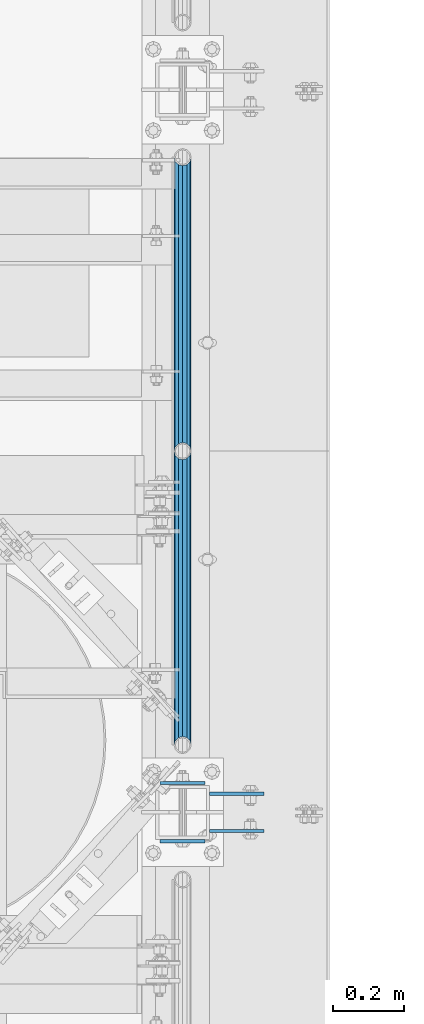
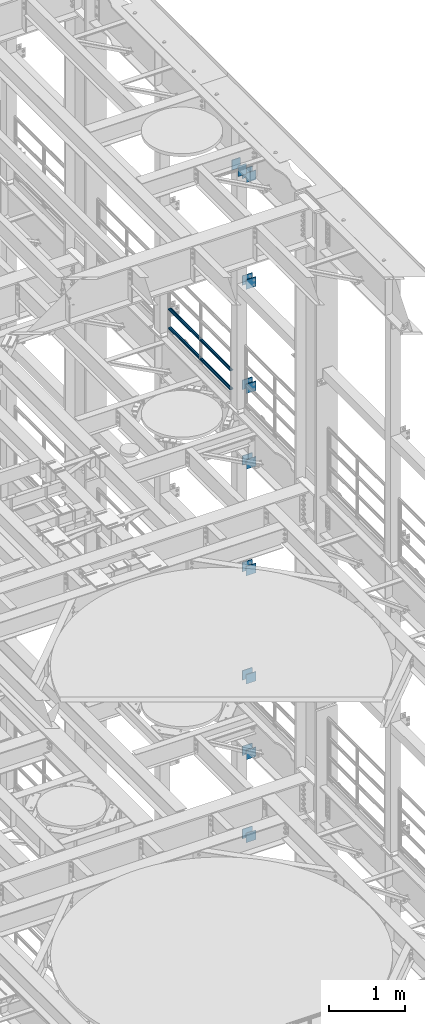
# One storey, part 1278 of 1876: 22 beams, 5 elements without a shape of their own.
"""IFC2X3 building model written with IfcOpenShell, lengths in millimetres."""

from ifc_helpers import new_model, si_unit, frame, origin_with_axes, place, context, subcontext, project, spatial, faceted_brep, material, type_object, element, aggregate, save


model = new_model("IFC2X3")

# Units and contexts
model_context = context("Model", 3, precision=1e-05, world=origin_with_axes())
body_context = subcontext(model_context, "Body", "Model", "MODEL_VIEW")
ifc_project = project(units=[si_unit("LENGTHUNIT", "METRE", prefix="MILLI"), si_unit("AREAUNIT", "SQUARE_METRE"), si_unit("VOLUMEUNIT", "CUBIC_METRE"), si_unit("MASSUNIT", "GRAM", prefix="KILO"), si_unit("TIMEUNIT", "SECOND"), si_unit("PLANEANGLEUNIT", "RADIAN"), si_unit("SOLIDANGLEUNIT", "STERADIAN"), si_unit("THERMODYNAMICTEMPERATUREUNIT", "DEGREE_CELSIUS"), si_unit("LUMINOUSINTENSITYUNIT", "LUMEN")], contexts=[model_context])

# Site, building, storey
site_placement = place(None, origin_with_axes())
site = spatial("IfcSite", under=ifc_project, at=site_placement, CompositionType="ELEMENT")
building_placement = place(site_placement, origin_with_axes())
building = spatial("IfcBuilding", under=site, at=building_placement, Name="Undefined", CompositionType="ELEMENT")
storey_placement = place(building_placement, origin_with_axes())
storey = spatial("IfcBuildingStorey", under=building, at=storey_placement, Name="Undefined", CompositionType="ELEMENT", Elevation=0.0)

# Assembly, beams
assembly_1_placement = place(storey_placement, origin_with_axes())
assembly_1 = element("IfcElementAssembly", 1, at=assembly_1_placement, inside=storey, Name="BEAM", AssemblyPlace="NOTDEFINED", PredefinedType="RIGID_FRAME")
ifc_material_1 = material(Name="STEEL/A36")
beam_type_1 = type_object("IfcBeamType", PredefinedType="NOTDEFINED")
beam_1_placement = place(assembly_1_placement, frame((7696.20000025489, 3608.3875, 18275.3), z_axis=(0.0, 0.0, -1.0), x_axis=(1.0, 0.0, 0.0)))
beam_1 = element("IfcBeam", 2, at=beam_1_placement, type_object=beam_type_1, material=ifc_material_1, Name="PLATE", context=body_context, shape_type="Brep", body=[
    faceted_brep([(0.0, 4.76249999999982, -76.1999999999998), (3.63797880709171e-12, 4.76249999999982, 76.1999969482422), (152.399993896484, 4.76250000000073, 76.1999969482422), (152.4, 4.76249999999982, -76.1999999999998), (3.63797880709171e-12, -4.76249999999982, 76.1999969482422), (152.399993896484, -4.76250000000073, 76.1999969482422), (0.0, -4.76249999999982, -76.1999999999998), (152.4, -4.76249999999982, -76.1999999999998)], [[[0, 1, 2, 3]], [[4, 5, 2, 1]], [[4, 6, 7, 5]], [[6, 0, 3, 7]], [[5, 7, 3, 2]], [[6, 4, 1, 0]]]),
])
beam_2_placement = place(assembly_1_placement, frame((7696.20000025489, 3503.6125, 18275.3), z_axis=(0.0, 0.0, -1.0), x_axis=(1.0, 0.0, 0.0)))
beam_2 = element("IfcBeam", 3, at=beam_2_placement, type_object=beam_type_1, material=ifc_material_1, Name="PLATE", context=body_context, shape_type="Brep", body=[
    faceted_brep([(0.0, 4.76249999999982, -76.1999999999998), (3.63797880709171e-12, 4.76249999999982, 76.1999969482422), (152.399993896484, 4.76250000000073, 76.1999969482422), (152.4, 4.76249999999982, -76.1999999999998), (3.63797880709171e-12, -4.76249999999982, 76.1999969482422), (152.399993896484, -4.76250000000073, 76.1999969482422), (0.0, -4.76249999999982, -76.1999999999998), (152.4, -4.76249999999982, -76.1999999999998)], [[[0, 1, 2, 3]], [[4, 5, 2, 1]], [[4, 6, 7, 5]], [[6, 0, 3, 7]], [[5, 7, 3, 2]], [[6, 4, 1, 0]]]),
])
beam_3_placement = place(assembly_1_placement, frame((7696.20000025489, 3608.3875, 21678.9), z_axis=(0.0, 0.0, -1.0), x_axis=(1.0, 0.0, 0.0)))
beam_3 = element("IfcBeam", 4, at=beam_3_placement, type_object=beam_type_1, material=ifc_material_1, Name="PLATE", context=body_context, shape_type="Brep", body=[
    faceted_brep([(0.0, 4.76249999999982, -76.1999999999998), (3.63797880709171e-12, 4.76249999999982, 76.1999969482422), (152.399993896484, 4.76250000000073, 76.1999969482422), (152.4, 4.76249999999982, -76.1999999999998), (3.63797880709171e-12, -4.76249999999982, 76.1999969482422), (152.399993896484, -4.76250000000073, 76.1999969482422), (0.0, -4.76249999999982, -76.1999999999998), (152.4, -4.76249999999982, -76.1999999999998)], [[[0, 1, 2, 3]], [[4, 5, 2, 1]], [[4, 6, 7, 5]], [[6, 0, 3, 7]], [[5, 7, 3, 2]], [[6, 4, 1, 0]]]),
])
beam_4_placement = place(assembly_1_placement, frame((7696.20000025489, 3503.6125, 21678.9), z_axis=(0.0, 0.0, -1.0), x_axis=(1.0, 0.0, 0.0)))
beam_4 = element("IfcBeam", 5, at=beam_4_placement, type_object=beam_type_1, material=ifc_material_1, Name="PLATE", context=body_context, shape_type="Brep", body=[
    faceted_brep([(0.0, 4.76249999999982, -76.1999999999998), (3.63797880709171e-12, 4.76249999999982, 76.1999969482422), (152.399993896484, 4.76250000000073, 76.1999969482422), (152.4, 4.76249999999982, -76.1999999999998), (3.63797880709171e-12, -4.76249999999982, 76.1999969482422), (152.399993896484, -4.76250000000073, 76.1999969482422), (0.0, -4.76249999999982, -76.1999999999998), (152.4, -4.76249999999982, -76.1999999999998)], [[[0, 1, 2, 3]], [[4, 5, 2, 1]], [[4, 6, 7, 5]], [[6, 0, 3, 7]], [[5, 7, 3, 2]], [[6, 4, 1, 0]]]),
])
beam_5_placement = place(assembly_1_placement, frame((7696.20000025489, 3608.3875, 19958.05), z_axis=(0.0, 0.0, -1.0), x_axis=(1.0, 0.0, 0.0)))
beam_5 = element("IfcBeam", 6, at=beam_5_placement, type_object=beam_type_1, material=ifc_material_1, Name="PLATE", context=body_context, shape_type="Brep", body=[
    faceted_brep([(0.0, 4.76249999999982, -76.1999999999998), (3.63797880709171e-12, 4.76249999999982, 76.1999969482422), (152.399993896484, 4.76250000000073, 76.1999969482422), (152.4, 4.76249999999982, -76.1999999999998), (3.63797880709171e-12, -4.76249999999982, 76.1999969482422), (152.399993896484, -4.76250000000073, 76.1999969482422), (0.0, -4.76249999999982, -76.1999999999998), (152.4, -4.76249999999982, -76.1999999999998)], [[[0, 1, 2, 3]], [[4, 5, 2, 1]], [[4, 6, 7, 5]], [[6, 0, 3, 7]], [[5, 7, 3, 2]], [[6, 4, 1, 0]]]),
])
beam_6_placement = place(assembly_1_placement, frame((7696.20000025489, 3503.6125, 19958.05), z_axis=(0.0, 0.0, -1.0), x_axis=(1.0, 0.0, 0.0)))
beam_6 = element("IfcBeam", 7, at=beam_6_placement, type_object=beam_type_1, material=ifc_material_1, Name="PLATE", context=body_context, shape_type="Brep", body=[
    faceted_brep([(0.0, 4.76249999999982, -76.1999999999998), (3.63797880709171e-12, 4.76249999999982, 76.1999969482422), (152.399993896484, 4.76250000000073, 76.1999969482422), (152.4, 4.76249999999982, -76.1999999999998), (3.63797880709171e-12, -4.76249999999982, 76.1999969482422), (152.399993896484, -4.76250000000073, 76.1999969482422), (0.0, -4.76249999999982, -76.1999999999998), (152.4, -4.76249999999982, -76.1999999999998)], [[[0, 1, 2, 3]], [[4, 5, 2, 1]], [[4, 6, 7, 5]], [[6, 0, 3, 7]], [[5, 7, 3, 2]], [[6, 4, 1, 0]]]),
])
aggregate(assembly_1, [beam_1, beam_2, beam_3, beam_4, beam_5, beam_6])

assembly_2_placement = place(storey_placement, origin_with_axes())
assembly_2 = element("IfcElementAssembly", 8, at=assembly_2_placement, inside=storey, Name="BEAM", AssemblyPlace="NOTDEFINED", PredefinedType="RIGID_FRAME")
beam_7_placement = place(assembly_2_placement, frame((7696.2, 3608.3875, 13589.0), z_axis=(0.0, 0.0, -1.0), x_axis=(1.0, 0.0, 0.0)))
beam_7 = element("IfcBeam", 9, at=beam_7_placement, type_object=beam_type_1, material=ifc_material_1, Name="PLATE", context=body_context, shape_type="Brep", body=[
    faceted_brep([(0.0, 4.76249999999982, -76.1999999999998), (3.63797880709171e-12, 4.76249999999982, 76.1999969482422), (152.399993896484, 4.76250000000073, 76.1999969482422), (152.4, 4.76249999999982, -76.1999999999998), (3.63797880709171e-12, -4.76249999999982, 76.1999969482422), (152.399993896484, -4.76250000000073, 76.1999969482422), (0.0, -4.76249999999982, -76.1999999999998), (152.4, -4.76249999999982, -76.1999999999998)], [[[0, 1, 2, 3]], [[4, 5, 2, 1]], [[4, 6, 7, 5]], [[6, 0, 3, 7]], [[5, 7, 3, 2]], [[6, 4, 1, 0]]]),
])
beam_8_placement = place(assembly_2_placement, frame((7696.2, 3503.6125, 13589.0), z_axis=(0.0, 0.0, -1.0), x_axis=(1.0, 0.0, 0.0)))
beam_8 = element("IfcBeam", 10, at=beam_8_placement, type_object=beam_type_1, material=ifc_material_1, Name="PLATE", context=body_context, shape_type="Brep", body=[
    faceted_brep([(0.0, 4.76249999999982, -76.1999999999998), (3.63797880709171e-12, 4.76249999999982, 76.1999969482422), (152.399993896484, 4.76250000000073, 76.1999969482422), (152.4, 4.76249999999982, -76.1999999999998), (3.63797880709171e-12, -4.76249999999982, 76.1999969482422), (152.399993896484, -4.76250000000073, 76.1999969482422), (0.0, -4.76249999999982, -76.1999999999998), (152.4, -4.76249999999982, -76.1999999999998)], [[[0, 1, 2, 3]], [[4, 5, 2, 1]], [[4, 6, 7, 5]], [[6, 0, 3, 7]], [[5, 7, 3, 2]], [[6, 4, 1, 0]]]),
])
beam_9_placement = place(assembly_2_placement, frame((7696.2, 3608.3875, 17056.1), z_axis=(0.0, 0.0, -1.0), x_axis=(1.0, 0.0, 0.0)))
beam_9 = element("IfcBeam", 11, at=beam_9_placement, type_object=beam_type_1, material=ifc_material_1, Name="PLATE", context=body_context, shape_type="Brep", body=[
    faceted_brep([(0.0, 4.76249999999982, -76.1999999999998), (3.63797880709171e-12, 4.76249999999982, 76.1999969482422), (152.399993896484, 4.76250000000073, 76.1999969482422), (152.4, 4.76249999999982, -76.1999999999998), (3.63797880709171e-12, -4.76249999999982, 76.1999969482422), (152.399993896484, -4.76250000000073, 76.1999969482422), (0.0, -4.76249999999982, -76.1999999999998), (152.4, -4.76249999999982, -76.1999999999998)], [[[0, 1, 2, 3]], [[4, 5, 2, 1]], [[4, 6, 7, 5]], [[6, 0, 3, 7]], [[5, 7, 3, 2]], [[6, 4, 1, 0]]]),
])
beam_10_placement = place(assembly_2_placement, frame((7696.2, 3503.6125, 17056.1), z_axis=(0.0, 0.0, -1.0), x_axis=(1.0, 0.0, 0.0)))
beam_10 = element("IfcBeam", 12, at=beam_10_placement, type_object=beam_type_1, material=ifc_material_1, Name="PLATE", context=body_context, shape_type="Brep", body=[
    faceted_brep([(0.0, 4.76249999999982, -76.1999999999998), (3.63797880709171e-12, 4.76249999999982, 76.1999969482422), (152.399993896484, 4.76250000000073, 76.1999969482422), (152.4, 4.76249999999982, -76.1999999999998), (3.63797880709171e-12, -4.76249999999982, 76.1999969482422), (152.399993896484, -4.76250000000073, 76.1999969482422), (0.0, -4.76249999999982, -76.1999999999998), (152.4, -4.76249999999982, -76.1999999999998)], [[[0, 1, 2, 3]], [[4, 5, 2, 1]], [[4, 6, 7, 5]], [[6, 0, 3, 7]], [[5, 7, 3, 2]], [[6, 4, 1, 0]]]),
])
beam_11_placement = place(assembly_2_placement, frame((7696.2, 3608.3875, 15335.25), z_axis=(0.0, 0.0, -1.0), x_axis=(1.0, 0.0, 0.0)))
beam_11 = element("IfcBeam", 13, at=beam_11_placement, type_object=beam_type_1, material=ifc_material_1, Name="PLATE", context=body_context, shape_type="Brep", body=[
    faceted_brep([(0.0, 4.76249999999982, -76.1999999999998), (3.63797880709171e-12, 4.76249999999982, 76.1999969482422), (152.399993896484, 4.76250000000073, 76.1999969482422), (152.4, 4.76249999999982, -76.1999999999998), (3.63797880709171e-12, -4.76249999999982, 76.1999969482422), (152.399993896484, -4.76250000000073, 76.1999969482422), (0.0, -4.76249999999982, -76.1999999999998), (152.4, -4.76249999999982, -76.1999999999998)], [[[0, 1, 2, 3]], [[4, 5, 2, 1]], [[4, 6, 7, 5]], [[6, 0, 3, 7]], [[5, 7, 3, 2]], [[6, 4, 1, 0]]]),
])
beam_12_placement = place(assembly_2_placement, frame((7696.2, 3503.6125, 15335.25), z_axis=(0.0, 0.0, -1.0), x_axis=(1.0, 0.0, 0.0)))
beam_12 = element("IfcBeam", 14, at=beam_12_placement, type_object=beam_type_1, material=ifc_material_1, Name="PLATE", context=body_context, shape_type="Brep", body=[
    faceted_brep([(0.0, 4.76249999999982, -76.1999999999998), (3.63797880709171e-12, 4.76249999999982, 76.1999969482422), (152.399993896484, 4.76250000000073, 76.1999969482422), (152.4, 4.76249999999982, -76.1999999999998), (3.63797880709171e-12, -4.76249999999982, 76.1999969482422), (152.399993896484, -4.76250000000073, 76.1999969482422), (0.0, -4.76249999999982, -76.1999999999998), (152.4, -4.76249999999982, -76.1999999999998)], [[[0, 1, 2, 3]], [[4, 5, 2, 1]], [[4, 6, 7, 5]], [[6, 0, 3, 7]], [[5, 7, 3, 2]], [[6, 4, 1, 0]]]),
])
aggregate(assembly_2, [beam_7, beam_8, beam_9, beam_10, beam_11, beam_12])

assembly_3_placement = place(storey_placement, origin_with_axes())
assembly_3 = element("IfcElementAssembly", 15, at=assembly_3_placement, inside=storey, Name="BEAM", AssemblyPlace="NOTDEFINED", PredefinedType="RIGID_FRAME")
beam_13_placement = place(assembly_3_placement, frame((7696.2, 3608.3875, 12369.8), z_axis=(0.0, 0.0, -1.0), x_axis=(1.0, 0.0, 0.0)))
beam_13 = element("IfcBeam", 16, at=beam_13_placement, type_object=beam_type_1, material=ifc_material_1, Name="PLATE", context=body_context, shape_type="Brep", body=[
    faceted_brep([(0.0, 4.76249999999982, -76.1999999999998), (3.63797880709171e-12, 4.76249999999982, 76.1999969482422), (152.399993896484, 4.76250000000073, 76.1999969482422), (152.4, 4.76249999999982, -76.1999999999998), (3.63797880709171e-12, -4.76249999999982, 76.1999969482422), (152.399993896484, -4.76250000000073, 76.1999969482422), (0.0, -4.76249999999982, -76.1999999999998), (152.4, -4.76249999999982, -76.1999999999998)], [[[0, 1, 2, 3]], [[4, 5, 2, 1]], [[4, 6, 7, 5]], [[6, 0, 3, 7]], [[5, 7, 3, 2]], [[6, 4, 1, 0]]]),
])
beam_14_placement = place(assembly_3_placement, frame((7696.2, 3503.6125, 12369.8), z_axis=(0.0, 0.0, -1.0), x_axis=(1.0, 0.0, 0.0)))
beam_14 = element("IfcBeam", 17, at=beam_14_placement, type_object=beam_type_1, material=ifc_material_1, Name="PLATE", context=body_context, shape_type="Brep", body=[
    faceted_brep([(0.0, 4.76249999999982, -76.1999999999998), (3.63797880709171e-12, 4.76249999999982, 76.1999969482422), (152.399993896484, 4.76250000000073, 76.1999969482422), (152.4, 4.76249999999982, -76.1999999999998), (3.63797880709171e-12, -4.76249999999982, 76.1999969482422), (152.399993896484, -4.76250000000073, 76.1999969482422), (0.0, -4.76249999999982, -76.1999999999998), (152.4, -4.76249999999982, -76.1999999999998)], [[[0, 1, 2, 3]], [[4, 5, 2, 1]], [[4, 6, 7, 5]], [[6, 0, 3, 7]], [[5, 7, 3, 2]], [[6, 4, 1, 0]]]),
])
beam_15_placement = place(assembly_3_placement, frame((7696.2, 3608.3875, 11029.95), z_axis=(0.0, 0.0, -1.0), x_axis=(1.0, 0.0, 0.0)))
beam_15 = element("IfcBeam", 18, at=beam_15_placement, type_object=beam_type_1, material=ifc_material_1, Name="PLATE", context=body_context, shape_type="Brep", body=[
    faceted_brep([(0.0, 4.76249999999982, -76.1999999999998), (3.63797880709171e-12, 4.76249999999982, 76.1999969482422), (152.399993896484, 4.76250000000073, 76.1999969482422), (152.4, 4.76249999999982, -76.1999999999998), (3.63797880709171e-12, -4.76249999999982, 76.1999969482422), (152.399993896484, -4.76250000000073, 76.1999969482422), (0.0, -4.76249999999982, -76.1999999999998), (152.4, -4.76249999999982, -76.1999999999998)], [[[0, 1, 2, 3]], [[4, 5, 2, 1]], [[4, 6, 7, 5]], [[6, 0, 3, 7]], [[5, 7, 3, 2]], [[6, 4, 1, 0]]]),
])
beam_16_placement = place(assembly_3_placement, frame((7696.2, 3503.6125, 11029.95), z_axis=(0.0, 0.0, -1.0), x_axis=(1.0, 0.0, 0.0)))
beam_16 = element("IfcBeam", 19, at=beam_16_placement, type_object=beam_type_1, material=ifc_material_1, Name="PLATE", context=body_context, shape_type="Brep", body=[
    faceted_brep([(0.0, 4.76249999999982, -76.1999999999998), (3.63797880709171e-12, 4.76249999999982, 76.1999969482422), (152.399993896484, 4.76250000000073, 76.1999969482422), (152.4, 4.76249999999982, -76.1999999999998), (3.63797880709171e-12, -4.76249999999982, 76.1999969482422), (152.399993896484, -4.76250000000073, 76.1999969482422), (0.0, -4.76249999999982, -76.1999999999998), (152.4, -4.76249999999982, -76.1999999999998)], [[[0, 1, 2, 3]], [[4, 5, 2, 1]], [[4, 6, 7, 5]], [[6, 0, 3, 7]], [[5, 7, 3, 2]], [[6, 4, 1, 0]]]),
])
aggregate(assembly_3, [beam_13, beam_14, beam_15, beam_16])

assembly_4_placement = place(storey_placement, origin_with_axes())
assembly_4 = element("IfcElementAssembly", 20, at=assembly_4_placement, inside=storey, Name="RAIL", AssemblyPlace="NOTDEFINED", PredefinedType="RIGID_FRAME")
ifc_material_2 = material()
beam_type_2 = type_object("IfcBeamType", Name="PIPE1-1/2SCH40", PredefinedType="NOTDEFINED")
beam_17_placement = place(assembly_4_placement, frame((7620.0, 4572.0, 18145.125), z_axis=(0.0, 0.0, 1.0), x_axis=(0.0, -1.0, 0.0)))
beam_17 = element("IfcBeam", 21, at=beam_17_placement, type_object=beam_type_2, material=ifc_material_2, Name="RAIL", ObjectType="PIPE1-1/2SCH40", context=body_context, shape_type="Brep", body=[
    faceted_brep([(805.872807006681, -12.0649999999996, 20.8971929933177), (805.872807006683, -12.0649999999996, 15.8661214311796), (805.379378568819, -10.2235000000001, 17.7076214311819), (802.640000000001, 0.0, 20.4470000000001), (802.640000000001, 0.0, 24.130000000001), (805.379378568819, 10.2235000000001, 17.7076214311819), (805.872807006683, 12.0649999999996, 15.8661214311796), (805.872807006681, 12.0649999999996, 20.8971929933177), (826.77, 24.1300000000001, 0.0), (814.705, 20.8971929933186, 12.0649999999987), (814.705, 20.8971929933186, -12.0649999999987), (811.515428437862, 17.7076214311801, 10.2235000000001), (814.254807006682, 20.4470000000001, 0.0), (811.515428437862, 17.7076214311801, -10.2235000000001), (805.872807006683, 12.0649999999996, -15.8661214311796), (805.872807006681, 12.0649999999996, -20.8971929933177), (805.379378568819, 10.2235000000001, -17.7076214311819), (802.640000000001, 0.0, -20.4470000000001), (802.640000000001, 0.0, -24.130000000001), (805.872807006683, -12.0649999999996, -15.8661214311796), (805.872807006681, -12.0649999999996, -20.8971929933177), (805.379378568819, -10.2235000000001, -17.7076214311819), (826.77, -24.1300000000001, 0.0), (814.705, -20.8971929933186, -12.0649999999987), (814.705, -20.8971929933186, 12.0649999999987), (811.515428437862, -17.7076214311801, -10.2235000000001), (814.254807006682, -20.4470000000001, 0.0), (811.515428437862, -17.7076214311801, 10.2235000000001), (12.0650000000064, -20.8971929933177, -12.0649999999987), (20.8971929933249, -12.0650000000005, -20.8971929933177), (0.0, 24.1299999999992, 0.0), (12.0650000000064, 20.8971929933177, -12.0649999999987), (12.0650000000064, 20.8971929933177, 12.0649999999987), (20.8971929933249, 12.0650000000005, 20.8971929933177), (24.1300000000064, 0.0, 24.130000000001), (20.8971929933249, 12.0650000000005, -20.8971929933177), (24.1300000000063, 0.0, -24.130000000001), (24.1300000000063, 0.0, -20.4470000000001), (20.8971929933249, -12.0650000000005, -15.8661214311796), (21.3906214311868, -10.2235000000001, -17.7076214311819), (21.3906214311868, 10.2235000000001, -17.7076214311819), (20.8971929933249, 12.0650000000005, -15.8661214311796), (15.2545715621445, 17.7076214311801, -10.2235000000001), (12.5151929933249, 20.4470000000001, 0.0), (15.2545715621445, 17.7076214311801, 10.2235000000001), (20.8971929933249, 12.0650000000005, 15.8661214311796), (21.3906214311868, 10.2235000000001, 17.7076214311819), (24.1300000000064, 0.0, 20.4470000000001), (21.3906214311868, -10.2235000000001, 17.7076214311819), (20.8971929933249, -12.0650000000005, 15.8661214311796), (20.8971929933249, -12.0650000000005, 20.8971929933177), (12.0650000000064, -20.8971929933177, 12.0649999999987), (0.0, -24.1299999999992, 0.0), (15.2545715621445, -17.7076214311801, 10.2235000000001), (12.5151929933249, -20.4470000000001, 0.0), (15.2545715621445, -17.7076214311801, -10.2235000000001)], [[[0, 1, 2, 3, 4]], [[4, 3, 5, 6, 7]], [[8, 9, 10]], [[7, 6, 11, 12, 13, 14, 15, 10, 9]], [[16, 17, 18, 15, 14]], [[19, 20, 18, 17, 21]], [[22, 23, 24]], [[24, 23, 20, 19, 25, 26, 27, 1, 0]], [[28, 29, 20, 23]], [[30, 31, 32]], [[33, 34, 4, 7]], [[32, 33, 7, 9]], [[30, 32, 9, 8]], [[31, 30, 8, 10]], [[35, 31, 10, 15]], [[36, 35, 15, 18]], [[29, 36, 18, 20]], [[37, 36, 29, 38, 39]], [[40, 41, 35, 36, 37]], [[32, 31, 35, 41, 42, 43, 44, 45, 33]], [[33, 45, 46, 47, 34]], [[34, 47, 48, 49, 50]], [[34, 50, 0, 4]], [[50, 51, 24, 0]], [[51, 52, 22, 24]], [[52, 28, 23, 22]], [[51, 28, 52]], [[50, 49, 53, 54, 55, 38, 29, 28, 51]], [[55, 54, 26, 25]], [[21, 39, 38, 55, 25, 19]], [[37, 39, 21, 17]], [[40, 37, 17, 16]], [[42, 41, 40, 16, 14, 13]], [[43, 42, 13, 12]], [[44, 43, 12, 11]], [[5, 46, 45, 44, 11, 6]], [[47, 46, 5, 3]], [[48, 47, 3, 2]], [[53, 49, 48, 2, 1, 27]], [[54, 53, 27, 26]]]),
])
beam_18_placement = place(assembly_4_placement, frame((7620.0, 5398.77, 18145.125), z_axis=(0.0, 0.0, 1.0), x_axis=(0.0, -1.0, 0.0)))
beam_18 = element("IfcBeam", 22, at=beam_18_placement, type_object=beam_type_2, material=ifc_material_2, Name="RAIL", ObjectType="PIPE1-1/2SCH40", context=body_context, shape_type="Brep", body=[
    faceted_brep([(805.872807006681, -12.0649999999996, 20.8971929933177), (805.872807006683, -12.0649999999996, 15.8661214311796), (805.379378568819, -10.2235000000001, 17.7076214311819), (802.640000000001, 0.0, 20.4470000000001), (802.640000000001, 0.0, 24.130000000001), (805.379378568819, 10.2235000000001, 17.7076214311819), (805.872807006683, 12.0649999999996, 15.8661214311796), (805.872807006681, 12.0649999999996, 20.8971929933177), (826.77, 24.1300000000001, 0.0), (814.705, 20.8971929933186, 12.0649999999987), (814.705, 20.8971929933186, -12.0649999999987), (811.515428437862, 17.7076214311801, 10.2235000000001), (814.254807006682, 20.4470000000001, 0.0), (811.515428437862, 17.7076214311801, -10.2235000000001), (805.872807006683, 12.0649999999996, -15.8661214311796), (805.872807006681, 12.0649999999996, -20.8971929933177), (805.379378568819, 10.2235000000001, -17.7076214311819), (802.640000000001, 0.0, -20.4470000000001), (802.640000000001, 0.0, -24.130000000001), (805.872807006683, -12.0649999999996, -15.8661214311796), (805.872807006681, -12.0649999999996, -20.8971929933177), (805.379378568819, -10.2235000000001, -17.7076214311819), (826.77, -24.1300000000001, 0.0), (814.705, -20.8971929933186, -12.0649999999987), (814.705, -20.8971929933186, 12.0649999999987), (811.515428437862, -17.7076214311801, -10.2235000000001), (814.254807006682, -20.4470000000001, 0.0), (811.515428437862, -17.7076214311801, 10.2235000000001), (12.0650000000064, -20.8971929933177, -12.0649999999987), (20.8971929933249, -12.0650000000005, -20.8971929933177), (0.0, 24.1299999999992, 0.0), (12.0650000000064, 20.8971929933177, -12.0649999999987), (12.0650000000064, 20.8971929933177, 12.0649999999987), (20.8971929933249, 12.0650000000005, 20.8971929933177), (24.1300000000064, 0.0, 24.130000000001), (20.8971929933249, 12.0650000000005, -20.8971929933177), (24.1300000000063, 0.0, -24.130000000001), (24.1300000000063, 0.0, -20.4470000000001), (20.8971929933249, -12.0650000000005, -15.8661214311796), (21.3906214311868, -10.2235000000001, -17.7076214311819), (21.3906214311868, 10.2235000000001, -17.7076214311819), (20.8971929933249, 12.0650000000005, -15.8661214311796), (15.2545715621445, 17.7076214311801, -10.2235000000001), (12.5151929933249, 20.4470000000001, 0.0), (15.2545715621445, 17.7076214311801, 10.2235000000001), (20.8971929933249, 12.0650000000005, 15.8661214311796), (21.3906214311868, 10.2235000000001, 17.7076214311819), (24.1300000000064, 0.0, 20.4470000000001), (21.3906214311868, -10.2235000000001, 17.7076214311819), (20.8971929933249, -12.0650000000005, 15.8661214311796), (20.8971929933249, -12.0650000000005, 20.8971929933177), (12.0650000000064, -20.8971929933177, 12.0649999999987), (0.0, -24.1299999999992, 0.0), (15.2545715621445, -17.7076214311801, 10.2235000000001), (12.5151929933249, -20.4470000000001, 0.0), (15.2545715621445, -17.7076214311801, -10.2235000000001)], [[[0, 1, 2, 3, 4]], [[4, 3, 5, 6, 7]], [[8, 9, 10]], [[7, 6, 11, 12, 13, 14, 15, 10, 9]], [[16, 17, 18, 15, 14]], [[19, 20, 18, 17, 21]], [[22, 23, 24]], [[24, 23, 20, 19, 25, 26, 27, 1, 0]], [[28, 29, 20, 23]], [[30, 31, 32]], [[33, 34, 4, 7]], [[32, 33, 7, 9]], [[30, 32, 9, 8]], [[31, 30, 8, 10]], [[35, 31, 10, 15]], [[36, 35, 15, 18]], [[29, 36, 18, 20]], [[37, 36, 29, 38, 39]], [[40, 41, 35, 36, 37]], [[32, 31, 35, 41, 42, 43, 44, 45, 33]], [[33, 45, 46, 47, 34]], [[34, 47, 48, 49, 50]], [[34, 50, 0, 4]], [[50, 51, 24, 0]], [[51, 52, 22, 24]], [[52, 28, 23, 22]], [[51, 28, 52]], [[50, 49, 53, 54, 55, 38, 29, 28, 51]], [[55, 54, 26, 25]], [[21, 39, 38, 55, 25, 19]], [[37, 39, 21, 17]], [[40, 37, 17, 16]], [[42, 41, 40, 16, 14, 13]], [[43, 42, 13, 12]], [[44, 43, 12, 11]], [[5, 46, 45, 44, 11, 6]], [[47, 46, 5, 3]], [[48, 47, 3, 2]], [[53, 49, 48, 2, 1, 27]], [[54, 53, 27, 26]]]),
])
beam_19_placement = place(assembly_4_placement, frame((7620.0, 3745.23, 18449.925), z_axis=(0.0, 0.0, -1.0), x_axis=(0.0, 1.0, 0.0)))
beam_19 = element("IfcBeam", 23, at=beam_19_placement, type_object=beam_type_2, material=ifc_material_2, Name="RAIL", ObjectType="PIPE1-1/2SCH40", context=body_context, shape_type="Brep", body=[
    faceted_brep([(0.0, 24.1299999999992, 0.0), (12.0650000000064, 20.8971929933177, -12.0649999999987), (12.0650000000064, 20.8971929933177, 12.0649999999987), (12.0650000000064, -20.8971929933177, 12.0649999999987), (12.0650000000064, -20.8971929933177, -12.0649999999987), (0.0, -24.1299999999992, 0.0), (20.8971929933249, -12.0650000000005, 20.8971929933177), (20.8971929933249, -12.0650000000005, 15.8661214311796), (15.2545715621445, -17.7076214311801, 10.2235000000001), (12.5151929933249, -20.4470000000001, 0.0), (15.2545715621445, -17.7076214311801, -10.2235000000001), (20.8971929933249, -12.0650000000005, -15.8661214311796), (20.8971929933249, -12.0650000000005, -20.8971929933177), (24.1300000000063, 0.0, -20.4470000000001), (24.1300000000063, 0.0, -24.130000000001), (21.3906214311868, -10.2235000000001, -17.7076214311819), (21.3906214311868, 10.2235000000001, -17.7076214311819), (20.8971929933249, 12.0650000000005, -15.8661214311796), (20.8971929933249, 12.0650000000005, -20.8971929933177), (15.2545715621445, 17.7076214311801, -10.2235000000001), (12.5151929933249, 20.4470000000001, 0.0), (15.2545715621445, 17.7076214311801, 10.2235000000001), (20.8971929933249, 12.0650000000005, 15.8661214311796), (20.8971929933249, 12.0650000000005, 20.8971929933177), (21.3906214311868, 10.2235000000001, 17.7076214311819), (24.1300000000064, 0.0, 20.4470000000001), (24.1300000000064, 0.0, 24.130000000001), (21.3906214311868, -10.2235000000001, 17.7076214311819), (826.77, 24.1300000000001, 0.0), (814.705, 20.8971929933186, -12.0649999999987), (805.872807006681, 12.0649999999996, -20.8971929933177), (826.77, -24.1300000000001, 0.0), (814.705, -20.8971929933186, -12.0649999999987), (814.705, -20.8971929933186, 12.0649999999987), (805.872807006681, -12.0649999999996, 20.8971929933177), (805.872807006681, -12.0649999999996, -20.8971929933177), (802.640000000001, 0.0, -24.130000000001), (805.379378568819, 10.2235000000001, -17.7076214311819), (802.640000000001, 0.0, -20.4470000000001), (805.872807006683, 12.0649999999996, -15.8661214311796), (805.872807006683, -12.0649999999996, -15.8661214311796), (805.379378568819, -10.2235000000001, -17.7076214311819), (811.515428437862, -17.7076214311801, -10.2235000000001), (814.254807006682, -20.4470000000001, 0.0), (811.515428437862, -17.7076214311801, 10.2235000000001), (805.872807006683, -12.0649999999996, 15.8661214311796), (805.379378568819, -10.2235000000001, 17.7076214311819), (802.640000000001, 0.0, 20.4470000000001), (802.640000000001, 0.0, 24.130000000001), (805.872807006681, 12.0649999999996, 20.8971929933177), (814.705, 20.8971929933186, 12.0649999999987), (805.872807006683, 12.0649999999996, 15.8661214311796), (811.515428437862, 17.7076214311801, 10.2235000000001), (814.254807006682, 20.4470000000001, 0.0), (811.515428437862, 17.7076214311801, -10.2235000000001), (805.379378568819, 10.2235000000001, 17.7076214311819)], [[[0, 1, 2]], [[3, 4, 5]], [[6, 7, 8, 9, 10, 11, 12, 4, 3]], [[13, 14, 12, 11, 15]], [[16, 17, 18, 14, 13]], [[2, 1, 18, 17, 19, 20, 21, 22, 23]], [[23, 22, 24, 25, 26]], [[26, 25, 27, 7, 6]], [[1, 0, 28, 29]], [[18, 1, 29, 30]], [[31, 32, 33]], [[6, 3, 33, 34]], [[3, 5, 31, 33]], [[5, 4, 32, 31]], [[4, 12, 35, 32]], [[12, 14, 36, 35]], [[14, 18, 30, 36]], [[37, 38, 36, 30, 39]], [[40, 35, 36, 38, 41]], [[33, 32, 35, 40, 42, 43, 44, 45, 34]], [[34, 45, 46, 47, 48]], [[26, 6, 34, 48]], [[2, 23, 49, 50]], [[23, 26, 48, 49]], [[0, 2, 50, 28]], [[28, 50, 29]], [[49, 51, 52, 53, 54, 39, 30, 29, 50]], [[48, 47, 55, 51, 49]], [[25, 24, 55, 47]], [[55, 24, 22, 21, 52, 51]], [[21, 20, 53, 52]], [[20, 19, 54, 53]], [[19, 17, 16, 37, 39, 54]], [[16, 13, 38, 37]], [[13, 15, 41, 38]], [[41, 15, 11, 10, 42, 40]], [[10, 9, 43, 42]], [[9, 8, 44, 43]], [[8, 7, 27, 46, 45, 44]], [[27, 25, 47, 46]]]),
])
beam_20_placement = place(assembly_4_placement, frame((7620.0, 4572.0, 18449.925), z_axis=(0.0, 0.0, -1.0), x_axis=(0.0, 1.0, 0.0)))
beam_20 = element("IfcBeam", 24, at=beam_20_placement, type_object=beam_type_2, material=ifc_material_2, Name="RAIL", ObjectType="PIPE1-1/2SCH40", context=body_context, shape_type="Brep", body=[
    faceted_brep([(0.0, 24.1299999999992, 0.0), (12.0650000000064, 20.8971929933177, -12.0649999999987), (12.0650000000064, 20.8971929933177, 12.0649999999987), (12.0650000000064, -20.8971929933177, 12.0649999999987), (12.0650000000064, -20.8971929933177, -12.0649999999987), (0.0, -24.1299999999992, 0.0), (20.8971929933249, -12.0650000000005, 20.8971929933177), (20.8971929933249, -12.0650000000005, 15.8661214311796), (15.2545715621445, -17.7076214311801, 10.2235000000001), (12.5151929933249, -20.4470000000001, 0.0), (15.2545715621445, -17.7076214311801, -10.2235000000001), (20.8971929933249, -12.0650000000005, -15.8661214311796), (20.8971929933249, -12.0650000000005, -20.8971929933177), (24.1300000000063, 0.0, -20.4470000000001), (24.1300000000063, 0.0, -24.130000000001), (21.3906214311868, -10.2235000000001, -17.7076214311819), (21.3906214311868, 10.2235000000001, -17.7076214311819), (20.8971929933249, 12.0650000000005, -15.8661214311796), (20.8971929933249, 12.0650000000005, -20.8971929933177), (15.2545715621445, 17.7076214311801, -10.2235000000001), (12.5151929933249, 20.4470000000001, 0.0), (15.2545715621445, 17.7076214311801, 10.2235000000001), (20.8971929933249, 12.0650000000005, 15.8661214311796), (20.8971929933249, 12.0650000000005, 20.8971929933177), (21.3906214311868, 10.2235000000001, 17.7076214311819), (24.1300000000064, 0.0, 20.4470000000001), (24.1300000000064, 0.0, 24.130000000001), (21.3906214311868, -10.2235000000001, 17.7076214311819), (826.77, 24.1300000000001, 0.0), (814.705, 20.8971929933186, -12.0649999999987), (805.872807006681, 12.0649999999996, -20.8971929933177), (826.77, -24.1300000000001, 0.0), (814.705, -20.8971929933186, -12.0649999999987), (814.705, -20.8971929933186, 12.0649999999987), (805.872807006681, -12.0649999999996, 20.8971929933177), (805.872807006681, -12.0649999999996, -20.8971929933177), (802.640000000001, 0.0, -24.130000000001), (805.379378568819, 10.2235000000001, -17.7076214311819), (802.640000000001, 0.0, -20.4470000000001), (805.872807006683, 12.0649999999996, -15.8661214311796), (805.872807006683, -12.0649999999996, -15.8661214311796), (805.379378568819, -10.2235000000001, -17.7076214311819), (811.515428437862, -17.7076214311801, -10.2235000000001), (814.254807006682, -20.4470000000001, 0.0), (811.515428437862, -17.7076214311801, 10.2235000000001), (805.872807006683, -12.0649999999996, 15.8661214311796), (805.379378568819, -10.2235000000001, 17.7076214311819), (802.640000000001, 0.0, 20.4470000000001), (802.640000000001, 0.0, 24.130000000001), (805.872807006681, 12.0649999999996, 20.8971929933177), (814.705, 20.8971929933186, 12.0649999999987), (805.872807006683, 12.0649999999996, 15.8661214311796), (811.515428437862, 17.7076214311801, 10.2235000000001), (814.254807006682, 20.4470000000001, 0.0), (811.515428437862, 17.7076214311801, -10.2235000000001), (805.379378568819, 10.2235000000001, 17.7076214311819)], [[[0, 1, 2]], [[3, 4, 5]], [[6, 7, 8, 9, 10, 11, 12, 4, 3]], [[13, 14, 12, 11, 15]], [[16, 17, 18, 14, 13]], [[2, 1, 18, 17, 19, 20, 21, 22, 23]], [[23, 22, 24, 25, 26]], [[26, 25, 27, 7, 6]], [[1, 0, 28, 29]], [[18, 1, 29, 30]], [[31, 32, 33]], [[6, 3, 33, 34]], [[3, 5, 31, 33]], [[5, 4, 32, 31]], [[4, 12, 35, 32]], [[12, 14, 36, 35]], [[14, 18, 30, 36]], [[37, 38, 36, 30, 39]], [[40, 35, 36, 38, 41]], [[33, 32, 35, 40, 42, 43, 44, 45, 34]], [[34, 45, 46, 47, 48]], [[26, 6, 34, 48]], [[2, 23, 49, 50]], [[23, 26, 48, 49]], [[0, 2, 50, 28]], [[28, 50, 29]], [[49, 51, 52, 53, 54, 39, 30, 29, 50]], [[48, 47, 55, 51, 49]], [[25, 24, 55, 47]], [[55, 24, 22, 21, 52, 51]], [[21, 20, 53, 52]], [[20, 19, 54, 53]], [[19, 17, 16, 37, 39, 54]], [[16, 13, 38, 37]], [[13, 15, 41, 38]], [[41, 15, 11, 10, 42, 40]], [[10, 9, 43, 42]], [[9, 8, 44, 43]], [[8, 7, 27, 46, 45, 44]], [[27, 25, 47, 46]]]),
])
aggregate(assembly_4, [beam_17, beam_18, beam_19, beam_20])

assembly_5_placement = place(storey_placement, origin_with_axes())
assembly_5 = element("IfcElementAssembly", 25, at=assembly_5_placement, inside=storey, Name="BEAM", AssemblyPlace="NOTDEFINED", PredefinedType="RIGID_FRAME")
beam_type_3 = type_object("IfcBeamType", PredefinedType="NOTDEFINED")
beam_21_placement = place(assembly_5_placement, frame((7556.5, 3638.55, 21850.35), z_axis=(0.0, 0.0, -1.0), x_axis=(1.0, 0.0, 0.0)))
beam_21 = element("IfcBeam", 26, at=beam_21_placement, type_object=beam_type_3, material=ifc_material_1, Name="PLATE", context=body_context, shape_type="Brep", body=[
    faceted_brep([(0.0, 4.76249999999982, -82.5499999999993), (0.0, 4.76249999999982, 82.5499999999993), (127.0, 4.76249999999982, 82.5499999999993), (127.0, 4.76249999999982, -82.5499999999993), (0.0, -4.76249999999982, 82.5499999999993), (127.0, -4.76249999999982, 82.5499999999993), (0.0, -4.76249999999982, -82.5499999999993), (127.0, -4.76249999999982, -82.5499999999993)], [[[0, 1, 2, 3]], [[1, 4, 5, 2]], [[4, 6, 7, 5]], [[6, 0, 3, 7]], [[5, 7, 3, 2]], [[6, 4, 1, 0]]]),
])
beam_22_placement = place(assembly_5_placement, frame((7556.5, 3475.0375, 21850.35), z_axis=(0.0, 0.0, -1.0), x_axis=(1.0, 0.0, 0.0)))
beam_22 = element("IfcBeam", 27, at=beam_22_placement, type_object=beam_type_3, material=ifc_material_1, Name="PLATE", context=body_context, shape_type="Brep", body=[
    faceted_brep([(0.0, 4.76249999999982, -82.5499999999993), (0.0, 4.76249999999982, 82.5499999999993), (127.0, 4.76249999999982, 82.5499999999993), (127.0, 4.76249999999982, -82.5499999999993), (0.0, -4.76249999999982, 82.5499999999993), (127.0, -4.76249999999982, 82.5499999999993), (0.0, -4.76249999999982, -82.5499999999993), (127.0, -4.76249999999982, -82.5499999999993)], [[[0, 1, 2, 3]], [[1, 4, 5, 2]], [[4, 6, 7, 5]], [[6, 0, 3, 7]], [[5, 7, 3, 2]], [[6, 4, 1, 0]]]),
])
aggregate(assembly_5, [beam_21, beam_22])

save(model, "model.ifc")
